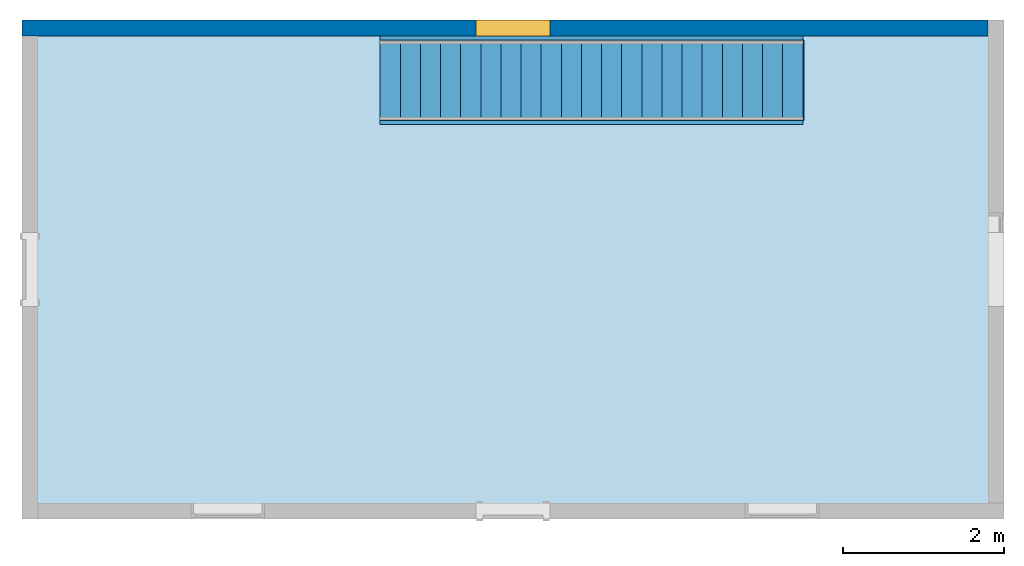
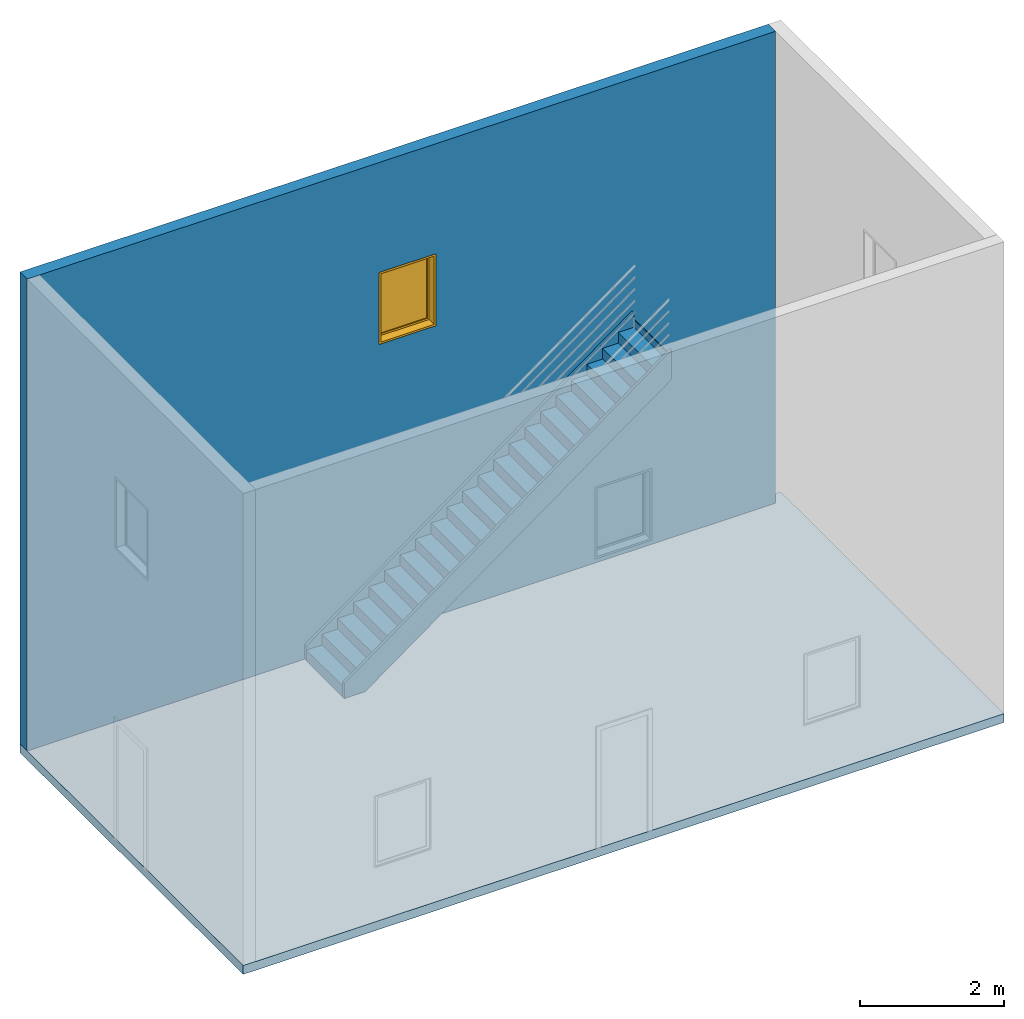
"""IFC4 building model written with IfcOpenShell, lengths in millimetres."""

from ifc_helpers import new_model, entity, si_unit, converted_unit, derived_unit, direction, frame, frame_2d, origin, origin_2d_with_axis, place, context, subcontext, project, spatial, polyline, rectangle, outline, extrude, polygons, source, transform, mapped, material, layer, layer_set, layer_usage, constituent, constituent_set, type_object, type_shapes, element, fill, aggregate, save


model = new_model("IFC4")

# Units and contexts
model_context = context("Model", 3, precision=0.01, world=origin(), true_north=direction((6.12303176911189e-17, 1.0)))
body_context = subcontext(model_context, "Body", "Model", "MODEL_VIEW")
ifc_project = project(units=[si_unit("LENGTHUNIT", "METRE", prefix="MILLI"), si_unit("AREAUNIT", "SQUARE_METRE"), si_unit("VOLUMEUNIT", "CUBIC_METRE"), converted_unit("PLANEANGLEUNIT", "DEGREE", entity("IfcRatioMeasure", 0.0174532925199433), si_unit("PLANEANGLEUNIT", "RADIAN"), dimensions=[0, 0, 0, 0, 0, 0, 0]), si_unit("MASSUNIT", "GRAM", prefix="KILO"), derived_unit("MASSDENSITYUNIT", [(si_unit("MASSUNIT", "GRAM", prefix="KILO"), 1), (si_unit("LENGTHUNIT", "METRE"), -3)]), si_unit("TIMEUNIT", "SECOND"), si_unit("FREQUENCYUNIT", "HERTZ"), si_unit("THERMODYNAMICTEMPERATUREUNIT", "DEGREE_CELSIUS"), derived_unit("THERMALTRANSMITTANCEUNIT", [(si_unit("MASSUNIT", "GRAM", prefix="KILO"), 1), (si_unit("THERMODYNAMICTEMPERATUREUNIT", "KELVIN"), -1), (si_unit("TIMEUNIT", "SECOND"), -3)]), derived_unit("VOLUMETRICFLOWRATEUNIT", [(si_unit("LENGTHUNIT", "METRE"), 3), (si_unit("TIMEUNIT", "SECOND"), -1)]), si_unit("ELECTRICCURRENTUNIT", "AMPERE"), si_unit("ELECTRICVOLTAGEUNIT", "VOLT"), si_unit("POWERUNIT", "WATT"), si_unit("FORCEUNIT", "NEWTON", prefix="KILO"), si_unit("ILLUMINANCEUNIT", "LUX"), si_unit("LUMINOUSFLUXUNIT", "LUMEN"), si_unit("LUMINOUSINTENSITYUNIT", "CANDELA"), derived_unit("USERDEFINED", [(si_unit("MASSUNIT", "GRAM", prefix="KILO"), -1), (si_unit("LENGTHUNIT", "METRE"), -2), (si_unit("TIMEUNIT", "SECOND"), 3), (si_unit("LUMINOUSFLUXUNIT", "LUMEN"), 1)]), derived_unit("LINEARVELOCITYUNIT", [(si_unit("LENGTHUNIT", "METRE"), 1), (si_unit("TIMEUNIT", "SECOND"), -1)]), si_unit("PRESSUREUNIT", "PASCAL"), derived_unit("USERDEFINED", [(si_unit("LENGTHUNIT", "METRE"), -2), (si_unit("MASSUNIT", "GRAM", prefix="KILO"), 1), (si_unit("TIMEUNIT", "SECOND"), -2)])], contexts=[model_context])

# Site, building, storey
site_placement = place(None, origin())
site = spatial("IfcSite", under=ifc_project, at=site_placement, CompositionType="ELEMENT")
building_placement = place(site_placement, origin())
building = spatial("IfcBuilding", under=site, at=building_placement, CompositionType="ELEMENT")
storey_1_placement = place(building_placement, origin())
storey_1 = spatial("IfcBuildingStorey", under=building, at=storey_1_placement, CompositionType="ELEMENT", Elevation=0.0)

# Stair, members
stair_placement = place(storey_1_placement, origin())
stair = element("IfcStair", 1, at=stair_placement, inside=storey_1, Name="Assembled Stair:Stair", PredefinedType="NOTDEFINED")
member_type = type_object("IfcMemberType", Name="Stringer:50mm", PredefinedType="STRINGER")
member_1_placement = place(stair_placement, origin())
member_1 = element("IfcMember", 2, at=member_1_placement, type_object=member_type, Name="Assembled Stair:Stair:337334 Stringer 1", PredefinedType="STRINGER", context=body_context, shape_type="SweptSolid", body=[
    extrude(outline(polyline([(-2534.0294804372, -200.44220991278), (3957.58144418654, -200.442209912781), (3666.67235327745, 199.557790087218), (-2409.13225508858, 199.55779008722), (-2681.09206193821, 1.76883965112204), (-2534.0294804372, -200.44220991278)])), frame((552.232705261415, 3830.3067966361, 1578.3729941465), z_axis=(0.0, 1.0, 0.0), x_axis=(0.808736084303189, 0.0, 0.588171697675046)), (0.0, 0.0, 1.0), 50.0),
])
member_2_placement = place(stair_placement, origin())
member_2 = element("IfcMember", 3, at=member_2_placement, type_object=member_type, Name="Assembled Stair:Stair:337334 Stringer 2", PredefinedType="STRINGER", context=body_context, shape_type="SweptSolid", body=[
    extrude(outline(polyline([(-2534.02948043719, -200.44220991278), (3957.58144418654, -200.442209912782), (3666.67235327745, 199.557790087219), (-2409.13225508858, 199.55779008722), (-2681.09206193822, 1.76883965112285), (-2534.02948043719, -200.44220991278)])), frame((552.232705261412, 2780.3067966361, 1578.3729941465), z_axis=(0.0, 1.0, 0.0), x_axis=(0.808736084303189, 0.0, 0.588171697675046)), (0.0, 0.0, 1.0), 50.0),
])

# Slab
ifc_material_1 = material()
ifc_layer_1 = layer(ifc_material_1, 150.0)
ifc_layer_set_1 = layer_set([ifc_layer_1], Name="Floor:150mm")
ifc_layer_usage_1 = layer_usage(ifc_layer_set_1, "AXIS3", "POSITIVE", 0.0)
slab_placement = place(storey_1_placement, origin())
element("IfcSlab", 4, at=slab_placement, inside=storey_1, material=ifc_layer_usage_1, Name="Floor:150mm", ObjectType="Floor:150mm", PredefinedType="FLOOR", context=body_context, shape_type="SweptSolid", body=[
    extrude(rectangle(XDim=6200.0, YDim=12200.0, at=origin_2d_with_axis()), frame((34.9771908536559, 980.306796636107, 0.0), z_axis=(0.0, 0.0, -1.0), x_axis=(0.0, 1.0, 0.0)), (0.0, 0.0, 1.0), 150.0),
])

# Wall, opening
ifc_material_2 = material()
ifc_layer_2 = layer(ifc_material_2, 200.0)
ifc_layer_set_2 = layer_set([ifc_layer_2], Name="Basic Wall:200mm")
ifc_layer_usage_2 = layer_usage(ifc_layer_set_2, "AXIS2", "NEGATIVE", 100.0)
wall_type = type_object("IfcWallType", Name="Basic Wall:200mm", PredefinedType="NOTDEFINED", material=ifc_layer_set_2)
wall_placement = place(storey_1_placement, frame((-6065.02280914634, 3980.30679663611, 0.0)))
wall = element("IfcWall", 5, at=wall_placement, inside=storey_1, type_object=wall_type, material=ifc_layer_usage_2, Name="Basic Wall:200mm", ObjectType="Basic Wall:200mm:398", PredefinedType="NOTDEFINED", context=body_context, shape_type="Tessellation", body=[
    polygons([(0.0, -100.0, 0.0), (200.0, -100.0, 2.0169972056493e-21), (12000.0, -100.0, 0.0), (12000.0, -100.0, 8000.00000000018), (199.999999999999, -100.0, 8000.00000000018), (1.08286712929839e-12, -100.0, 8000.00000000018), (5642.5, -100.0, 4915.0), (5642.5, -100.0, 6135.0), (6557.5, -100.0, 6135.0), (6557.5, -100.0, 4915.0), (1.08286712929839e-12, 100.0, 2.0169972056493e-21), (0.0, 100.0, 8000.00000000018), (12000.0, 100.0, 8000.00000000018), (12000.0, 100.0, -6.05099161694791e-21), (5642.5, 100.0, 4915.0), (6557.5, 100.0, 4915.0), (6557.5, 100.0, 6135.0), (5642.5, 100.0, 6135.0)], [[[3, 4, 5, 6, 1, 2], [10, 7, 8, 9]], [[2, 1, 11, 14, 3]], [[12, 11, 1, 6]], [[5, 4, 13, 12, 6]], [[8, 7, 15, 18]], [[9, 8, 18, 17]], [[7, 10, 16, 15]], [[10, 9, 17, 16]], [[3, 14, 13, 4]], [[12, 13, 14, 11], [15, 16, 17, 18]]], closed=True),
])
opening_placement = place(wall_placement, frame((5642.5, -100.0, 4915.0)))
opening = element("IfcOpeningElement", 6, at=opening_placement, cuts=wall, ObjectType="Opening", PredefinedType="OPENING", context=body_context, shape_type="SweptSolid", body=[
    extrude(rectangle(XDim=1220.0, YDim=914.999999999999, at=frame_2d((609.999999999999, 457.5), x_axis=(1.0, 0.0))), frame((0.0, 0.0, 0.0), z_axis=(0.0, 1.0, 0.0), x_axis=(0.0, 0.0, 1.0)), (0.0, 0.0, 1.0), 200.0),
])

# Storey
storey_2_placement = place(building_placement, frame((0.0, 0.0, 4000.0)))
storey_2 = spatial("IfcBuildingStorey", under=building, at=storey_2_placement, CompositionType="ELEMENT", Elevation=4000.0)

# Window
ifc_material_3 = material()
ifc_constituent_1 = constituent(ifc_material_3, Category="Materials")
ifc_material_4 = material()
ifc_constituent_2 = constituent(ifc_material_4, Category="Materials")
ifc_constituent_set_1 = constituent_set(constituents=[ifc_constituent_1, ifc_constituent_2])
ifc_constituent_3 = constituent(ifc_material_3, Category="Materials")
ifc_constituent_4 = constituent(ifc_material_4, Category="Materials")
ifc_constituent_set_2 = constituent_set(constituents=[ifc_constituent_3, ifc_constituent_4])
window_type = type_object("IfcWindowType", Name="0915 x 1220mm", ParameterTakesPrecedence=False, PartitioningType="NOTDEFINED", PredefinedType="WINDOW", material=ifc_constituent_set_2)
shared_shape = source(origin(), body_context, "Body", "SweptSolid", [
    extrude(rectangle(XDim=12.0, YDim=788.999999999997, at=frame_2d((8.43769498715119e-15, 0.0), x_axis=(1.0, 0.0))), frame((457.500000000006, 159.0, 63.0), z_axis=(0.0, 0.0, 1.0), x_axis=(0.0, -1.0, 0.0)), (0.0, 0.0, 1.0), 1094.00000000001),
    extrude(outline(polyline([(-438.5, -591.0), (438.5, -591.0), (438.5, 591.0), (-438.5, 591.0), (-438.5, -591.0)]), holes=[polyline([(-394.5, -547.0), (-394.5, 547.0), (394.499999999998, 547.0), (394.499999999998, -547.0), (-394.5, -547.0)])]), frame((457.500000000007, 137.0, 610.0), z_axis=(0.0, 1.0, 0.0), x_axis=(1.0, 0.0, 0.0)), (0.0, 0.0, 1.0), 44.0000000000274),
    extrude(outline(polyline([(-457.5, -610.0), (457.5, -610.0), (457.5, 610.0), (-457.5, 610.0), (-457.5, -610.0)]), holes=[polyline([(-438.500000000001, -591.0), (-438.500000000001, 591.0), (438.499999999999, 591.0), (438.499999999999, -591.0), (-438.500000000001, -591.0)])]), frame((457.500000000008, 137.0, 610.0), z_axis=(0.0, 1.0, 0.0), x_axis=(1.0, 0.0, 0.0)), (0.0, 0.0, 1.0), 63.0000000000274),
    extrude(outline(polyline([(-457.5, -610.0), (457.5, -610.0), (457.5, 610.0), (-457.5, 610.0), (-457.5, -610.0)]), holes=[polyline([(-425.5, -578.0), (-425.5, 578.0), (425.5, 578.0), (425.5, -578.0), (-425.5, -578.0)])]), frame((457.500000000008, 0.0, 610.0), z_axis=(0.0, 1.0, 0.0), x_axis=(1.0, 0.0, 0.0)), (0.0, 0.0, 1.0), 136.999999999973),
])
type_shapes(window_type, [shared_shape])
window_placement = place(opening_placement, origin())
window = element("IfcWindow", 7, at=window_placement, inside=storey_2, type_object=window_type, material=ifc_constituent_set_1, ObjectType="0915 x 1220mm", OverallHeight=1220.0, OverallWidth=914.999999999999, PartitioningType="NOTDEFINED", PredefinedType="WINDOW", context=body_context, shape_type="MappedRepresentation", body=[
    mapped(shared_shape, transform((0.0, 0.0, 0.0), scale=1.0)),
])

fill(opening, window)

# Stair flight
stair_flight_placement = place(stair_placement, origin())
stair_flight = element("IfcStairFlight", 8, at=stair_flight_placement, Name="Assembled Stair:Stair:337334 Run 1", NumberOfRisers=22, NumberOfTreads=21, PredefinedType="NOTDEFINED", RiserHeight=0.596516344547841, TreadLength=0.820209973753281, context=body_context, shape_type="SweptSolid", body=[
    extrude(rectangle(XDim=1000.0, YDim=12.4999999999999, at=origin_2d_with_axis()), frame((-1608.77280914634, 3330.30679663611, 0.0), z_axis=(0.0, 0.0, 1.0), x_axis=(0.0, 1.0, 0.0)), (0.0, 0.0, 1.0), 131.818181818182),
    extrude(rectangle(XDim=249.999999999999, YDim=1000.0, at=frame_2d((5.40012479177676e-13, -2.55795384873636e-13), x_axis=(1.0, 0.0))), frame((-1490.02280914634, 3330.30679663611, 131.818181818182), z_axis=(0.0, 0.0, 1.0), x_axis=(-1.0, 0.0, 0.0)), (0.0, 0.0, 1.0), 50.0),
    extrude(rectangle(XDim=1000.0, YDim=12.4999999999999, at=origin_2d_with_axis()), frame((-1358.77280914634, 3330.30679663611, 131.818181818182), z_axis=(0.0, 0.0, 1.0), x_axis=(0.0, 1.0, 0.0)), (0.0, 0.0, 1.0), 181.818181818182),
    extrude(rectangle(XDim=250.000000000001, YDim=1000.0, at=frame_2d((-5.47117906535277e-13, -5.40012479177676e-13), x_axis=(1.0, 0.0))), frame((-1240.02280914634, 3330.30679663611, 313.636363636364), z_axis=(0.0, 0.0, 1.0), x_axis=(-1.0, 0.0, 0.0)), (0.0, 0.0, 1.0), 50.0),
    extrude(rectangle(XDim=1000.0, YDim=12.4999999999999, at=origin_2d_with_axis()), frame((-1108.77280914635, 3330.30679663611, 313.636363636364), z_axis=(0.0, 0.0, 1.0), x_axis=(0.0, 1.0, 0.0)), (0.0, 0.0, 1.0), 181.818181818182),
    extrude(rectangle(XDim=250.000000000001, YDim=1000.0, at=frame_2d((-5.47117906535277e-13, 0.0), x_axis=(1.0, 0.0))), frame((-990.022809146346, 3330.30679663611, 495.454545454545), z_axis=(0.0, 0.0, 1.0), x_axis=(-1.0, 0.0, 0.0)), (0.0, 0.0, 1.0), 50.0),
    extrude(rectangle(XDim=1000.0, YDim=12.4999999999999, at=origin_2d_with_axis()), frame((-858.772809146345, 3330.30679663611, 495.454545454545), z_axis=(0.0, 0.0, 1.0), x_axis=(0.0, 1.0, 0.0)), (0.0, 0.0, 1.0), 181.818181818182),
    extrude(rectangle(XDim=250.000000000001, YDim=1000.0, at=frame_2d((-5.47117906535277e-13, 0.0), x_axis=(1.0, 0.0))), frame((-740.022809146345, 3330.30679663611, 677.272727272727), z_axis=(0.0, 0.0, 1.0), x_axis=(-1.0, 0.0, 0.0)), (0.0, 0.0, 1.0), 50.0),
    extrude(rectangle(XDim=1000.0, YDim=12.4999999999999, at=origin_2d_with_axis()), frame((-608.772809146346, 3330.30679663611, 677.272727272727), z_axis=(0.0, 0.0, 1.0), x_axis=(0.0, 1.0, 0.0)), (0.0, 0.0, 1.0), 181.818181818182),
    extrude(rectangle(XDim=250.000000000001, YDim=1000.0, at=frame_2d((-5.47117906535277e-13, 5.40012479177676e-13), x_axis=(1.0, 0.0))), frame((-490.022809146346, 3330.30679663611, 859.090909090909), z_axis=(0.0, 0.0, 1.0), x_axis=(-1.0, 0.0, 0.0)), (0.0, 0.0, 1.0), 50.0),
    extrude(rectangle(XDim=1000.0, YDim=12.4999999999999, at=origin_2d_with_axis()), frame((-358.772809146345, 3330.3067966361, 859.090909090909), z_axis=(0.0, 0.0, 1.0), x_axis=(0.0, 1.0, 0.0)), (0.0, 0.0, 1.0), 181.818181818182),
    extrude(rectangle(XDim=250.000000000001, YDim=1000.0, at=frame_2d((-5.47117906535277e-13, 0.0), x_axis=(1.0, 0.0))), frame((-240.022809146345, 3330.3067966361, 1040.90909090909), z_axis=(0.0, 0.0, 1.0), x_axis=(-1.0, 0.0, 0.0)), (0.0, 0.0, 1.0), 50.0),
    extrude(rectangle(XDim=1000.0, YDim=12.4999999999999, at=origin_2d_with_axis()), frame((-108.772809146346, 3330.3067966361, 1040.90909090909), z_axis=(0.0, 0.0, 1.0), x_axis=(0.0, 1.0, 0.0)), (0.0, 0.0, 1.0), 181.818181818182),
    extrude(rectangle(XDim=250.000000000001, YDim=1000.0, at=frame_2d((-5.47117906535277e-13, 0.0), x_axis=(1.0, 0.0))), frame((9.97719085365372, 3330.3067966361, 1222.72727272727), z_axis=(0.0, 0.0, 1.0), x_axis=(-1.0, 0.0, 0.0)), (0.0, 0.0, 1.0), 50.0),
    extrude(rectangle(XDim=1000.0, YDim=12.4999999999999, at=origin_2d_with_axis()), frame((141.227190853655, 3330.3067966361, 1222.72727272727), z_axis=(0.0, 0.0, 1.0), x_axis=(0.0, 1.0, 0.0)), (0.0, 0.0, 1.0), 181.818181818182),
    extrude(rectangle(XDim=250.000000000001, YDim=1000.0, at=frame_2d((-5.47117906535277e-13, 0.0), x_axis=(1.0, 0.0))), frame((259.977190853655, 3330.3067966361, 1404.54545454545), z_axis=(0.0, 0.0, 1.0), x_axis=(-1.0, 0.0, 0.0)), (0.0, 0.0, 1.0), 50.0),
    extrude(rectangle(XDim=1000.0, YDim=12.4999999999999, at=origin_2d_with_axis()), frame((391.227190853654, 3330.3067966361, 1404.54545454545), z_axis=(0.0, 0.0, 1.0), x_axis=(0.0, 1.0, 0.0)), (0.0, 0.0, 1.0), 181.818181818182),
    extrude(rectangle(XDim=250.000000000001, YDim=1000.0, at=frame_2d((-5.47117906535277e-13, 0.0), x_axis=(1.0, 0.0))), frame((509.977190853654, 3330.3067966361, 1586.36363636364), z_axis=(0.0, 0.0, 1.0), x_axis=(-1.0, 0.0, 0.0)), (0.0, 0.0, 1.0), 50.0),
    extrude(rectangle(XDim=1000.0, YDim=12.4999999999999, at=origin_2d_with_axis()), frame((641.227190853655, 3330.3067966361, 1586.36363636364), z_axis=(0.0, 0.0, 1.0), x_axis=(0.0, 1.0, 0.0)), (0.0, 0.0, 1.0), 181.818181818182),
    extrude(rectangle(XDim=250.000000000001, YDim=1000.0, at=frame_2d((-5.47117906535277e-13, 5.40012479177676e-13), x_axis=(1.0, 0.0))), frame((759.977190853655, 3330.3067966361, 1768.18181818182), z_axis=(0.0, 0.0, 1.0), x_axis=(-1.0, 0.0, 0.0)), (0.0, 0.0, 1.0), 50.0),
    extrude(rectangle(XDim=1000.0, YDim=12.4999999999999, at=origin_2d_with_axis()), frame((891.227190853653, 3330.3067966361, 1768.18181818182), z_axis=(0.0, 0.0, 1.0), x_axis=(0.0, 1.0, 0.0)), (0.0, 0.0, 1.0), 181.818181818182),
    extrude(rectangle(XDim=250.000000000001, YDim=1000.0, at=frame_2d((-5.47117906535277e-13, 0.0), x_axis=(1.0, 0.0))), frame((1009.97719085365, 3330.3067966361, 1950.0), z_axis=(0.0, 0.0, 1.0), x_axis=(-1.0, 0.0, 0.0)), (0.0, 0.0, 1.0), 50.0),
    extrude(rectangle(XDim=1000.0, YDim=12.4999999999999, at=origin_2d_with_axis()), frame((1141.22719085365, 3330.3067966361, 1950.0), z_axis=(0.0, 0.0, 1.0), x_axis=(0.0, 1.0, 0.0)), (0.0, 0.0, 1.0), 181.818181818182),
    extrude(rectangle(XDim=250.000000000001, YDim=1000.0, at=frame_2d((-5.47117906535277e-13, 0.0), x_axis=(1.0, 0.0))), frame((1259.97719085365, 3330.3067966361, 2131.81818181818), z_axis=(0.0, 0.0, 1.0), x_axis=(-1.0, 0.0, 0.0)), (0.0, 0.0, 1.0), 50.0),
    extrude(rectangle(XDim=1000.0, YDim=12.4999999999999, at=origin_2d_with_axis()), frame((1391.22719085365, 3330.3067966361, 2131.81818181818), z_axis=(0.0, 0.0, 1.0), x_axis=(0.0, 1.0, 0.0)), (0.0, 0.0, 1.0), 181.818181818182),
    extrude(rectangle(XDim=250.000000000001, YDim=1000.0, at=frame_2d((-5.47117906535277e-13, -5.40012479177676e-13), x_axis=(1.0, 0.0))), frame((1509.97719085365, 3330.3067966361, 2313.63636363636), z_axis=(0.0, 0.0, 1.0), x_axis=(-1.0, 0.0, 0.0)), (0.0, 0.0, 1.0), 50.0),
    extrude(rectangle(XDim=1000.0, YDim=12.4999999999999, at=origin_2d_with_axis()), frame((1641.22719085365, 3330.3067966361, 2313.63636363636), z_axis=(0.0, 0.0, 1.0), x_axis=(0.0, 1.0, 0.0)), (0.0, 0.0, 1.0), 181.818181818182),
    extrude(rectangle(XDim=250.000000000001, YDim=1000.0, at=frame_2d((-5.47117906535277e-13, 0.0), x_axis=(1.0, 0.0))), frame((1759.97719085365, 3330.3067966361, 2495.45454545455), z_axis=(0.0, 0.0, 1.0), x_axis=(-1.0, 0.0, 0.0)), (0.0, 0.0, 1.0), 50.0),
    extrude(rectangle(XDim=1000.0, YDim=12.4999999999999, at=origin_2d_with_axis()), frame((1891.22719085365, 3330.3067966361, 2495.45454545455), z_axis=(0.0, 0.0, 1.0), x_axis=(0.0, 1.0, 0.0)), (0.0, 0.0, 1.0), 181.818181818182),
    extrude(rectangle(XDim=250.000000000001, YDim=1000.0, at=frame_2d((-2.77111666946439e-13, 0.0), x_axis=(1.0, 0.0))), frame((2009.97719085365, 3330.3067966361, 2677.27272727273), z_axis=(0.0, 0.0, 1.0), x_axis=(-1.0, 0.0, 0.0)), (0.0, 0.0, 1.0), 50.0),
    extrude(rectangle(XDim=1000.0, YDim=12.4999999999999, at=origin_2d_with_axis()), frame((2141.22719085365, 3330.3067966361, 2677.27272727273), z_axis=(0.0, 0.0, 1.0), x_axis=(0.0, 1.0, 0.0)), (0.0, 0.0, 1.0), 181.818181818182),
    extrude(rectangle(XDim=250.000000000001, YDim=1000.0, at=frame_2d((-5.47117906535277e-13, 0.0), x_axis=(1.0, 0.0))), frame((2259.97719085365, 3330.3067966361, 2859.09090909091), z_axis=(0.0, 0.0, 1.0), x_axis=(-1.0, 0.0, 0.0)), (0.0, 0.0, 1.0), 50.0),
    extrude(rectangle(XDim=1000.0, YDim=12.4999999999999, at=origin_2d_with_axis()), frame((2391.22719085365, 3330.3067966361, 2859.09090909091), z_axis=(0.0, 0.0, 1.0), x_axis=(0.0, 1.0, 0.0)), (0.0, 0.0, 1.0), 181.818181818182),
    extrude(rectangle(XDim=250.000000000001, YDim=1000.0, at=frame_2d((-2.77111666946439e-13, 0.0), x_axis=(1.0, 0.0))), frame((2509.97719085365, 3330.30679663609, 3040.90909090909), z_axis=(0.0, 0.0, 1.0), x_axis=(-1.0, 0.0, 0.0)), (0.0, 0.0, 1.0), 50.0),
    extrude(rectangle(XDim=1000.0, YDim=12.4999999999999, at=frame_2d((0.0, -2.70894418008538e-13), x_axis=(1.0, 0.0))), frame((2641.22719085365, 3330.30679663609, 3040.90909090909), z_axis=(0.0, 0.0, 1.0), x_axis=(0.0, 1.0, 0.0)), (0.0, 0.0, 1.0), 181.818181818182),
    extrude(rectangle(XDim=250.000000000001, YDim=1000.0, at=frame_2d((-5.47117906535277e-13, -5.40012479177676e-13), x_axis=(1.0, 0.0))), frame((2759.97719085365, 3330.30679663609, 3222.72727272727), z_axis=(0.0, 0.0, 1.0), x_axis=(-1.0, 0.0, 0.0)), (0.0, 0.0, 1.0), 50.0),
    extrude(rectangle(XDim=1000.0, YDim=12.4999999999999, at=frame_2d((0.0, -2.70894418008538e-13), x_axis=(1.0, 0.0))), frame((2891.22719085365, 3330.30679663609, 3222.72727272727), z_axis=(0.0, 0.0, 1.0), x_axis=(0.0, 1.0, 0.0)), (0.0, 0.0, 1.0), 181.818181818182),
    extrude(rectangle(XDim=250.000000000001, YDim=1000.0, at=frame_2d((-8.17124146124115e-13, 0.0), x_axis=(1.0, 0.0))), frame((3009.97719085365, 3330.30679663609, 3404.54545454546), z_axis=(0.0, 0.0, 1.0), x_axis=(-1.0, 0.0, 0.0)), (0.0, 0.0, 1.0), 50.0),
    extrude(rectangle(XDim=1000.0, YDim=12.4999999999999, at=frame_2d((0.0, -2.70894418008538e-13), x_axis=(1.0, 0.0))), frame((3141.22719085365, 3330.30679663609, 3404.54545454546), z_axis=(0.0, 0.0, 1.0), x_axis=(0.0, 1.0, 0.0)), (0.0, 0.0, 1.0), 181.818181818182),
    extrude(rectangle(XDim=250.000000000001, YDim=1000.0, at=frame_2d((-2.77111666946439e-13, 0.0), x_axis=(1.0, 0.0))), frame((3259.97719085365, 3330.30679663609, 3586.36363636364), z_axis=(0.0, 0.0, 1.0), x_axis=(-1.0, 0.0, 0.0)), (0.0, 0.0, 1.0), 50.0),
    extrude(rectangle(XDim=1000.0, YDim=12.4999999999999, at=frame_2d((0.0, 2.70894418008538e-13), x_axis=(1.0, 0.0))), frame((3391.22719085366, 3330.30679663609, 3586.36363636364), z_axis=(0.0, 0.0, 1.0), x_axis=(0.0, 1.0, 0.0)), (0.0, 0.0, 1.0), 181.818181818182),
    extrude(rectangle(XDim=1000.0, YDim=12.4999999999999, at=frame_2d((0.0, -2.70894418008538e-13), x_axis=(1.0, 0.0))), frame((3641.22719085365, 3330.30679663609, 3768.18181818182), z_axis=(0.0, 0.0, 1.0), x_axis=(0.0, 1.0, 0.0)), (0.0, 0.0, 1.0), 181.818181818182),
    extrude(rectangle(XDim=250.000000000001, YDim=1000.0, at=frame_2d((-2.77111666946439e-13, 5.40012479177676e-13), x_axis=(1.0, 0.0))), frame((3509.97719085366, 3330.30679663609, 3768.18181818182), z_axis=(0.0, 0.0, 1.0), x_axis=(-1.0, 0.0, 0.0)), (0.0, 0.0, 1.0), 50.0),
])

aggregate(stair, [stair_flight, member_1, member_2])

save(model, "model.ifc")
